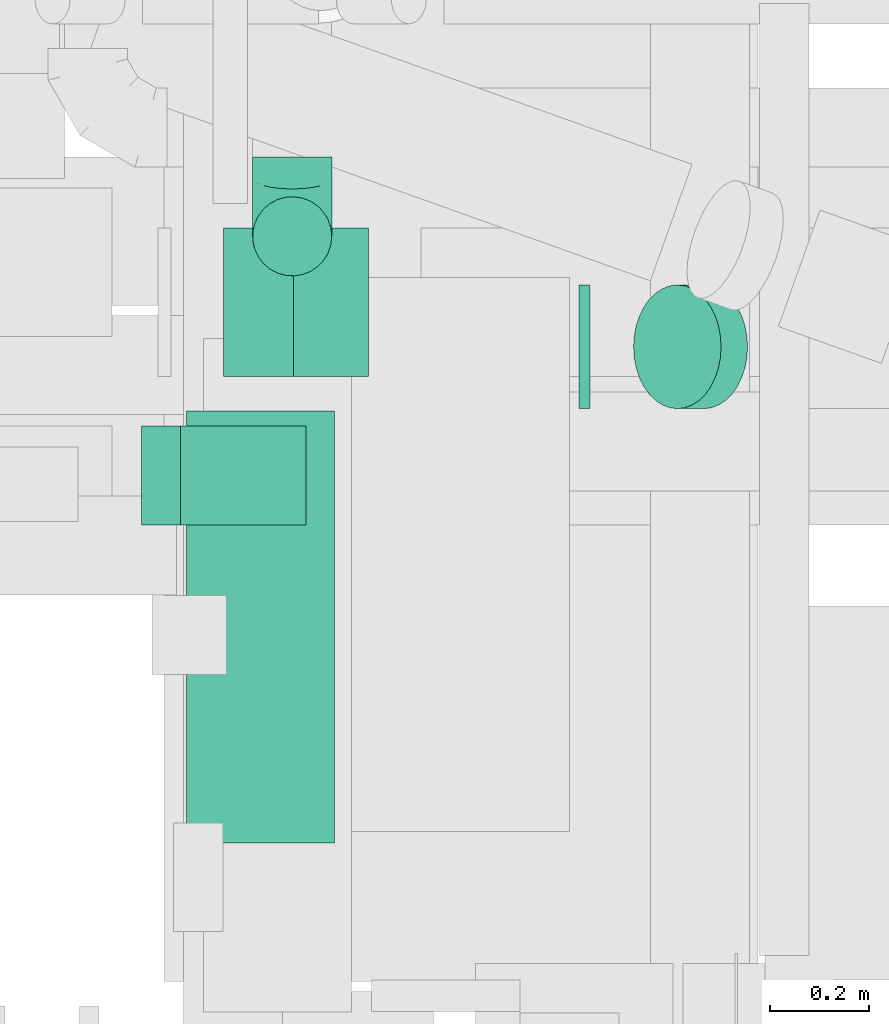
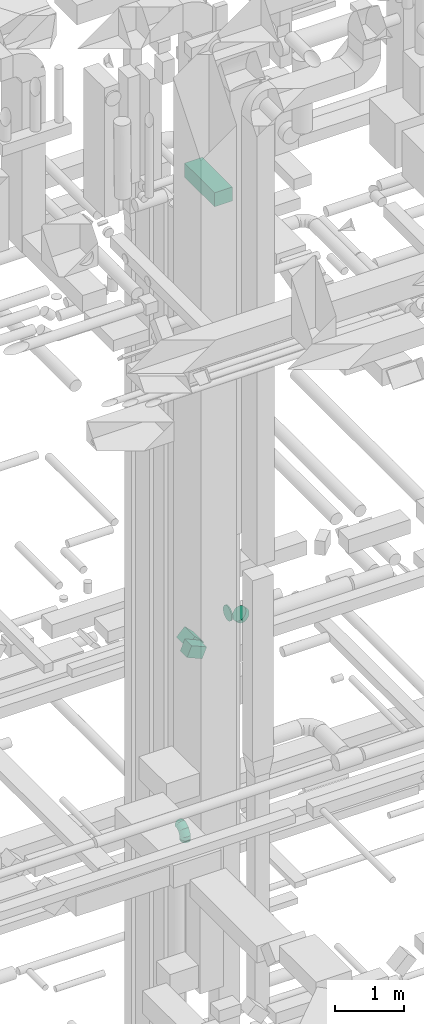
# One storey, part 203 of 337: 6 flow segments, 2 flow fittings.
"""IFC2X3 building model written with IfcOpenShell, lengths in millimetres."""

from ifc_helpers import new_model, entity, si_unit, converted_unit, derived_unit, direction, frame, frame_2d, origin, origin_2d_with_axis, place, context, subcontext, project, spatial, rectangle, circle, extrude, faceted_brep, source, transform, mapped, material, type_object, type_shapes, element, save


model = new_model("IFC2X3")

# Units and contexts
model_context = context("Model", 3, precision=0.01, world=origin(), true_north=direction((6.12303176911189e-17, 1.0)))
body_context = subcontext(model_context, "Body", "Model", "MODEL_VIEW")
ifc_project = project(units=[si_unit("LENGTHUNIT", "METRE", prefix="MILLI"), si_unit("AREAUNIT", "SQUARE_METRE"), si_unit("VOLUMEUNIT", "CUBIC_METRE"), converted_unit("PLANEANGLEUNIT", "DEGREE", entity("IfcRatioMeasure", 0.0174532925199433), si_unit("PLANEANGLEUNIT", "RADIAN"), dimensions=[0, 0, 0, 0, 0, 0, 0]), si_unit("MASSUNIT", "GRAM", prefix="KILO"), derived_unit("MASSDENSITYUNIT", [(si_unit("MASSUNIT", "GRAM", prefix="KILO"), 1), (si_unit("LENGTHUNIT", "METRE"), -3)]), derived_unit("MOMENTOFINERTIAUNIT", [(si_unit("LENGTHUNIT", "METRE"), 4)]), si_unit("TIMEUNIT", "SECOND"), si_unit("FREQUENCYUNIT", "HERTZ"), si_unit("THERMODYNAMICTEMPERATUREUNIT", "DEGREE_CELSIUS"), derived_unit("THERMALTRANSMITTANCEUNIT", [(si_unit("MASSUNIT", "GRAM", prefix="KILO"), 1), (si_unit("THERMODYNAMICTEMPERATUREUNIT", "KELVIN"), -1), (si_unit("TIMEUNIT", "SECOND"), -3)]), derived_unit("VOLUMETRICFLOWRATEUNIT", [(si_unit("LENGTHUNIT", "METRE"), 3), (si_unit("TIMEUNIT", "SECOND"), -1)]), derived_unit("MASSFLOWRATEUNIT", [(si_unit("MASSUNIT", "GRAM", prefix="KILO"), 1), (si_unit("TIMEUNIT", "SECOND"), -1)]), derived_unit("ROTATIONALFREQUENCYUNIT", [(si_unit("TIMEUNIT", "SECOND"), -1)]), si_unit("ELECTRICCURRENTUNIT", "AMPERE"), si_unit("ELECTRICVOLTAGEUNIT", "VOLT"), si_unit("POWERUNIT", "WATT"), si_unit("FORCEUNIT", "NEWTON", prefix="KILO"), si_unit("ILLUMINANCEUNIT", "LUX"), si_unit("LUMINOUSFLUXUNIT", "LUMEN"), si_unit("LUMINOUSINTENSITYUNIT", "CANDELA"), derived_unit("USERDEFINED", [(si_unit("MASSUNIT", "GRAM", prefix="KILO"), -1), (si_unit("LENGTHUNIT", "METRE"), -2), (si_unit("TIMEUNIT", "SECOND"), 3), (si_unit("LUMINOUSFLUXUNIT", "LUMEN"), 1)]), derived_unit("LINEARVELOCITYUNIT", [(si_unit("LENGTHUNIT", "METRE"), 1), (si_unit("TIMEUNIT", "SECOND"), -1)]), si_unit("PRESSUREUNIT", "PASCAL"), derived_unit("USERDEFINED", [(si_unit("LENGTHUNIT", "METRE"), -2), (si_unit("MASSUNIT", "GRAM", prefix="KILO"), 1), (si_unit("TIMEUNIT", "SECOND"), -2)]), derived_unit("LINEARFORCEUNIT", [(si_unit("MASSUNIT", "GRAM", prefix="KILO"), 1), (si_unit("LENGTHUNIT", "METRE"), 1), (si_unit("TIMEUNIT", "SECOND"), -2), (si_unit("LENGTHUNIT", "METRE"), -1)]), derived_unit("PLANARFORCEUNIT", [(si_unit("MASSUNIT", "GRAM", prefix="KILO"), 1), (si_unit("LENGTHUNIT", "METRE"), 1), (si_unit("TIMEUNIT", "SECOND"), -2), (si_unit("LENGTHUNIT", "METRE"), -2)])], contexts=[model_context])

# Site, building, storey
site_placement = place(None, origin())
site = spatial("IfcSite", under=ifc_project, at=site_placement, CompositionType="ELEMENT")
building_placement = place(site_placement, origin())
building = spatial("IfcBuilding", under=site, at=building_placement, CompositionType="ELEMENT")
storey_placement = place(building_placement, origin())
storey = spatial("IfcBuildingStorey", under=building, at=storey_placement, CompositionType="ELEMENT", Elevation=0.0)

# Flow segments
duct_segment_type_1 = type_object("IfcDuctSegmentType", PredefinedType="NOTDEFINED")
flow_segment_1_placement = place(storey_placement, frame((53191.54, 14375.32, 18679.52)))
element("IfcFlowSegment", 1, at=flow_segment_1_placement, inside=storey, type_object=duct_segment_type_1, context=body_context, shape_type="SweptSolid", body=[
    extrude(rectangle(XDim=214.31457505078, YDim=200.000000000003, at=origin_2d_with_axis()), frame((146.48, 0.0, 146.48), z_axis=(0.0, 1.0, 0.0), x_axis=(0.707106781186487, 0.0, -0.707106781186608)), (0.0, 0.0, 1.0), 300.000000000003),
])
flow_segment_2_placement = place(storey_placement, frame((53024.86, 14075.53, 18778.44)))
element("IfcFlowSegment", 2, at=flow_segment_2_placement, inside=storey, type_object=duct_segment_type_1, context=body_context, shape_type="SweptSolid", body=[
    extrude(rectangle(XDim=199.999999999999, YDim=200.000000000002, at=frame_2d((0.0, 0.0), x_axis=(0.0, 1.0))), frame((39.49, 100.0, 201.24), z_axis=(0.918736047311593, 0.0, -0.394872226638277), x_axis=(0.0, 1.0, 0.0)), (0.0, 0.0, 1.0), 276.970666149187),
])
flow_segment_3_placement = place(storey_placement, frame((53115.82, 13433.04, 27250.0)))
element("IfcFlowSegment", 3, at=flow_segment_3_placement, inside=storey, type_object=duct_segment_type_1, context=body_context, shape_type="SweptSolid", body=[
    extrude(rectangle(XDim=873.174964743788, YDim=300.000000000001, at=origin_2d_with_axis()), frame((150.0, 436.59, 0.0), z_axis=(0.0, 0.0, 1.0), x_axis=(0.0, 1.0, 0.0)), (0.0, 0.0, 1.0), 250.000000000004),
])
duct_segment_type_2 = type_object("IfcDuctSegmentType", PredefinedType="NOTDEFINED")
flow_segment_4_placement = place(storey_placement, frame((53910.04, 14308.92, 19023.4)))
element("IfcFlowSegment", 4, at=flow_segment_4_placement, inside=storey, type_object=duct_segment_type_2, context=body_context, shape_type="SweptSolid", body=[
    extrude(circle(Radius=125.0, at=origin_2d_with_axis()), frame((0.0, 126.6, 126.6), z_axis=(1.0, 0.0, 0.0), x_axis=(0.0, 1.0, 0.0)), (0.0, 0.0, 1.0), 21.446609406689),
])
flow_segment_5_placement = place(storey_placement, frame((54018.28, 14308.92, 18933.24)))
element("IfcFlowSegment", 5, at=flow_segment_5_placement, inside=storey, type_object=duct_segment_type_2, context=body_context, shape_type="SweptSolid", body=[
    extrude(circle(Radius=125.0, at=origin_2d_with_axis()), frame((143.54, 126.6, 89.98), z_axis=(-0.707106781186604, 0.0, 0.707106781186492), x_axis=(0.0, -1.0, 0.0)), (0.0, 0.0, 1.0), 75.7359312880897),
])
flow_segment_6_placement = place(storey_placement, frame((53248.32, 14577.31, 15220.0)))
element("IfcFlowSegment", 6, at=flow_segment_6_placement, inside=storey, type_object=duct_segment_type_2, context=body_context, shape_type="SweptSolid", body=[
    extrude(circle(Radius=80.0, at=origin_2d_with_axis()), frame((81.6, 81.6, 0.0)), (0.0, 0.0, 1.0), 9.99999999996524),
])

# Flow fittings
ifc_material = material()
duct_fitting_type_1 = type_object("IfcDuctFittingType", PredefinedType="NOTDEFINED", material=ifc_material)
shared_shape_1 = source(origin(), body_context, "Body", "Brep", [
    faceted_brep([(-160.0, 0.0, -80.0), (-160.0, -20.71, -77.27), (-160.0, -40.0, -69.28), (-160.0, -56.57, -56.57), (-160.0, -69.28, -40.0), (-160.0, -77.27, -20.71), (-160.0, -80.0, 0.0), (-160.0, -77.27, 20.71), (-160.0, -69.28, 40.0), (-160.0, -56.57, 56.57), (-160.0, -40.0, 69.28), (-160.0, -20.71, 77.27), (-160.0, 0.0, 80.0), (-160.0, 20.71, 77.27), (-160.0, 40.0, 69.28), (-160.0, 56.57, 56.57), (-160.0, 69.28, 40.0), (-160.0, 77.27, 20.71), (-160.0, 80.0, 0.0), (-160.0, 77.27, -20.71), (-160.0, 69.28, -40.0), (-160.0, 56.57, -56.57), (-160.0, 40.0, -69.28), (-160.0, 20.71, -77.27), (-122.68, 20.71, 77.27), (-127.85, 40.0, 69.28), (-117.13, 0.0, 80.0), (-132.29, 56.57, 56.57), (-137.83, 77.27, 20.71), (-138.56, 80.0, 0.0), (-135.69, 69.28, 40.0), (-135.69, 69.28, -40.0), (-132.29, 56.57, -56.57), (-137.83, 77.27, -20.71), (-122.68, 20.71, -77.27), (-117.13, 0.0, -80.0), (-127.85, 40.0, -69.28), (-111.58, -20.71, -77.27), (-106.41, -40.0, -69.28), (-101.97, -56.57, -56.57), (-98.56, -69.28, -40.0), (-96.42, -77.27, -20.71), (-95.69, -80.0, 0.0), (-96.42, -77.27, 20.71), (-98.56, -69.28, 40.0), (-101.97, -56.57, 56.57), (-106.41, -40.0, 69.28), (-111.58, -20.71, 77.27), (-58.03, 58.03, 77.27), (-72.15, 72.15, 69.28), (-42.87, 42.87, 80.0), (-84.28, 84.28, 56.57), (-93.59, 93.59, 40.0), (-99.44, 99.44, 20.71), (-101.44, 101.44, 0.0), (-99.44, 99.44, -20.71), (-93.59, 93.59, -40.0), (-84.28, 84.28, -56.57), (-58.03, 58.03, -77.27), (-42.87, 42.87, -80.0), (-72.15, 72.15, -69.28), (-27.71, 27.71, -77.27), (-13.59, 13.59, -69.28), (-1.46, 1.46, -56.57), (7.85, -7.85, -40.0), (13.7, -13.7, -20.71), (15.69, -15.69, 0.0), (13.7, -13.7, 20.71), (7.85, -7.85, 40.0), (-1.46, 1.46, 56.57), (-13.59, 13.59, 69.28), (-27.71, 27.71, 77.27), (-20.71, 122.68, 77.27), (-40.0, 127.85, 69.28), (0.0, 117.13, 80.0), (-56.57, 132.29, 56.57), (-69.28, 135.69, 40.0), (-77.27, 137.83, 20.71), (-80.0, 138.56, 0.0), (-77.27, 137.83, -20.71), (-69.28, 135.69, -40.0), (-56.57, 132.29, -56.57), (-20.71, 122.68, -77.27), (0.0, 117.13, -80.0), (-40.0, 127.85, -69.28), (20.71, 111.58, -77.27), (40.0, 106.41, -69.28), (56.57, 101.97, -56.57), (69.28, 98.56, -40.0), (77.27, 96.42, -20.71), (80.0, 95.69, 0.0), (77.27, 96.42, 20.71), (69.28, 98.56, 40.0), (56.57, 101.97, 56.57), (40.0, 106.41, 69.28), (20.71, 111.58, 77.27), (-20.71, 160.0, -77.27), (-40.0, 160.0, -69.28), (-56.57, 160.0, -56.57), (-69.28, 160.0, -40.0), (-77.27, 160.0, -20.71), (-80.0, 160.0, 0.0), (-77.27, 160.0, 20.71), (-69.28, 160.0, 40.0), (-56.57, 160.0, 56.57), (-40.0, 160.0, 69.28), (-20.71, 160.0, 77.27), (0.0, 160.0, 80.0), (20.71, 160.0, 77.27), (40.0, 160.0, 69.28), (56.57, 160.0, 56.57), (69.28, 160.0, 40.0), (77.27, 160.0, 20.71), (80.0, 160.0, 0.0), (77.27, 160.0, -20.71), (69.28, 160.0, -40.0), (56.57, 160.0, -56.57), (40.0, 160.0, -69.28), (20.71, 160.0, -77.27), (0.0, 160.0, -80.0)], [[[0, 1, 2, 3, 4, 5, 6, 7, 8, 9, 10, 11, 12, 13, 14, 15, 16, 17, 18, 19, 20, 21, 22, 23]], [[24, 25, 14, 13]], [[26, 24, 13, 12]], [[14, 25, 27, 15]], [[28, 29, 18, 17]], [[30, 28, 17, 16]], [[15, 27, 30, 16]], [[20, 31, 32, 21]], [[33, 31, 20, 19]], [[18, 29, 33, 19]], [[34, 35, 0, 23]], [[36, 34, 23, 22]], [[32, 36, 22, 21]], [[1, 0, 35, 37]], [[2, 1, 37, 38]], [[3, 2, 38, 39]], [[5, 4, 40, 41]], [[6, 5, 41, 42]], [[39, 40, 4, 3]], [[6, 42, 43, 7]], [[7, 43, 44, 8]], [[8, 44, 45, 9]], [[9, 45, 46, 10]], [[10, 46, 47, 11]], [[26, 12, 11, 47]], [[48, 49, 25, 24]], [[50, 48, 24, 26]], [[27, 25, 49, 51]], [[52, 53, 28, 30]], [[51, 52, 30, 27]], [[29, 28, 53, 54]], [[55, 56, 31, 33]], [[54, 55, 33, 29]], [[32, 31, 56, 57]], [[58, 59, 35, 34]], [[60, 58, 34, 36]], [[57, 60, 36, 32]], [[37, 35, 59, 61]], [[38, 37, 61, 62]], [[39, 38, 62, 63]], [[41, 40, 64, 65]], [[42, 41, 65, 66]], [[63, 64, 40, 39]], [[43, 42, 66, 67]], [[44, 43, 67, 68]], [[68, 69, 45, 44]], [[46, 45, 69, 70]], [[47, 46, 70, 71]], [[26, 47, 71, 50]], [[72, 73, 49, 48]], [[74, 72, 48, 50]], [[51, 49, 73, 75]], [[76, 77, 53, 52]], [[75, 76, 52, 51]], [[54, 53, 77, 78]], [[79, 80, 56, 55]], [[78, 79, 55, 54]], [[57, 56, 80, 81]], [[82, 83, 59, 58]], [[84, 82, 58, 60]], [[81, 84, 60, 57]], [[61, 59, 83, 85]], [[62, 61, 85, 86]], [[63, 62, 86, 87]], [[65, 64, 88, 89]], [[66, 65, 89, 90]], [[87, 88, 64, 63]], [[67, 66, 90, 91]], [[68, 67, 91, 92]], [[92, 93, 69, 68]], [[70, 69, 93, 94]], [[71, 70, 94, 95]], [[50, 71, 95, 74]], [[96, 97, 98, 99, 100, 101, 102, 103, 104, 105, 106, 107, 108, 109, 110, 111, 112, 113, 114, 115, 116, 117, 118, 119]], [[72, 74, 107, 106]], [[73, 72, 106, 105]], [[75, 73, 105, 104]], [[77, 76, 103, 102]], [[78, 77, 102, 101]], [[75, 104, 103, 76]], [[78, 101, 100, 79]], [[79, 100, 99, 80]], [[80, 99, 98, 81]], [[84, 97, 96, 82]], [[82, 96, 119, 83]], [[84, 81, 98, 97]], [[118, 117, 86, 85]], [[119, 118, 85, 83]], [[116, 87, 86, 117]], [[88, 115, 114, 89]], [[89, 114, 113, 90]], [[115, 88, 87, 116]], [[112, 111, 92, 91]], [[113, 112, 91, 90]], [[111, 110, 93, 92]], [[95, 94, 109, 108]], [[74, 95, 108, 107]], [[110, 109, 94, 93]]]),
])
type_shapes(duct_fitting_type_1, [shared_shape_1])
flow_fitting_1_placement = place(storey_placement, frame((53329.91, 14658.91, 15390.0), z_axis=(1.0, 0.0, 0.0), x_axis=(0.0, -1.0, 0.0)))
element("IfcFlowFitting", 7, at=flow_fitting_1_placement, inside=storey, type_object=duct_fitting_type_1, material=ifc_material, context=body_context, shape_type="MappedRepresentation", body=[
    mapped(shared_shape_1, transform((0.0, 0.0, 0.0), scale=1.0)),
])
duct_fitting_type_2 = type_object("IfcDuctFittingType", PredefinedType="NOTDEFINED", material=ifc_material)
shared_shape_2 = source(origin(), body_context, "Body", "Brep", [
    faceted_brep([(20.0, 0.0, -80.0), (20.0, 20.71, -77.27), (20.0, 40.0, -69.28), (20.0, 56.57, -56.57), (20.0, 69.28, -40.0), (20.0, 77.27, -20.71), (20.0, 80.0, 0.0), (20.0, 77.27, 20.71), (20.0, 69.28, 40.0), (20.0, 56.57, 56.57), (20.0, 40.0, 69.28), (20.0, 20.71, 77.27), (20.0, 0.0, 80.0), (20.0, -20.71, 77.27), (20.0, -40.0, 69.28), (20.0, -56.57, 56.57), (20.0, -69.28, 40.0), (20.0, -77.27, 20.71), (20.0, -80.0, 0.0), (20.0, -77.27, -20.71), (20.0, -69.28, -40.0), (20.0, -56.57, -56.57), (20.0, -40.0, -69.28), (20.0, -20.71, -77.27), (0.0, 0.0, 80.0), (-6.1, 0.0, 80.0), (-6.1, -20.71, 77.27), (0.0, -20.71, 77.27), (-6.1, -40.0, 69.28), (0.0, -40.0, 69.28), (0.0, -56.57, 56.57), (-6.1, -56.57, 56.57), (0.0, -69.28, 40.0), (-6.1, -69.28, 40.0), (-6.1, -77.27, 20.71), (0.0, -77.27, 20.71), (-6.1, -80.0, 0.0), (0.0, -80.0, 0.0), (-6.1, -77.27, -20.71), (0.0, -77.27, -20.71), (-6.1, -69.28, -40.0), (0.0, -69.28, -40.0), (0.0, -56.57, -56.57), (-6.1, -56.57, -56.57), (0.0, -40.0, -69.28), (-6.1, -40.0, -69.28), (-6.1, -20.71, -77.27), (0.0, -20.71, -77.27), (-6.1, 0.0, -80.0), (0.0, 0.0, -80.0), (-6.1, 20.71, -77.27), (0.0, 20.71, -77.27), (-6.1, 40.0, -69.28), (0.0, 40.0, -69.28), (0.0, 56.57, -56.57), (-6.1, 56.57, -56.57), (0.0, 69.28, -40.0), (-6.1, 69.28, -40.0), (-6.1, 77.27, -20.71), (0.0, 77.27, -20.71), (-6.1, 80.0, 0.0), (0.0, 80.0, 0.0), (-6.1, 77.27, 20.71), (0.0, 77.27, 20.71), (-6.1, 69.28, 40.0), (0.0, 69.28, 40.0), (0.0, 56.57, 56.57), (-6.1, 56.57, 56.57), (0.0, 40.0, 69.28), (-6.1, 40.0, 69.28), (-6.1, 20.71, 77.27), (0.0, 20.71, 77.27)], [[[0, 1, 2, 3, 4, 5, 6, 7, 8, 9, 10, 11, 12, 13, 14, 15, 16, 17, 18, 19, 20, 21, 22, 23]], [[13, 12, 24, 25, 26, 27]], [[14, 13, 27, 26, 28, 29]], [[30, 15, 14, 29, 28, 31]], [[17, 16, 32, 33, 34, 35]], [[18, 17, 35, 34, 36, 37]], [[32, 16, 15, 30, 31, 33]], [[19, 18, 37, 36, 38, 39]], [[20, 19, 39, 38, 40, 41]], [[42, 21, 20, 41, 40, 43]], [[23, 22, 44, 45, 46, 47]], [[0, 23, 47, 46, 48, 49]], [[44, 22, 21, 42, 43, 45]], [[1, 0, 49, 48, 50, 51]], [[2, 1, 51, 50, 52, 53]], [[54, 3, 2, 53, 52, 55]], [[5, 4, 56, 57, 58, 59]], [[6, 5, 59, 58, 60, 61]], [[56, 4, 3, 54, 55, 57]], [[7, 6, 61, 60, 62, 63]], [[8, 7, 63, 62, 64, 65]], [[66, 9, 8, 65, 64, 67]], [[11, 10, 68, 69, 70, 71]], [[12, 11, 71, 70, 25, 24]], [[68, 10, 9, 66, 67, 69]], [[46, 45, 43, 40, 38, 36, 34, 33, 31, 28, 26, 25, 70, 69, 67, 64, 62, 60, 58, 57, 55, 52, 50, 48]]]),
])
type_shapes(duct_fitting_type_2, [shared_shape_2])
flow_fitting_2_placement = place(storey_placement, frame((53329.91, 14658.91, 15200.0), z_axis=(0.0, 1.0, 0.0), x_axis=(0.0, 0.0, 1.0)))
element("IfcFlowFitting", 8, at=flow_fitting_2_placement, inside=storey, type_object=duct_fitting_type_2, material=ifc_material, context=body_context, shape_type="MappedRepresentation", body=[
    mapped(shared_shape_2, transform((0.0, 0.0, 0.0), scale=1.0)),
])

save(model, "model.ifc")
